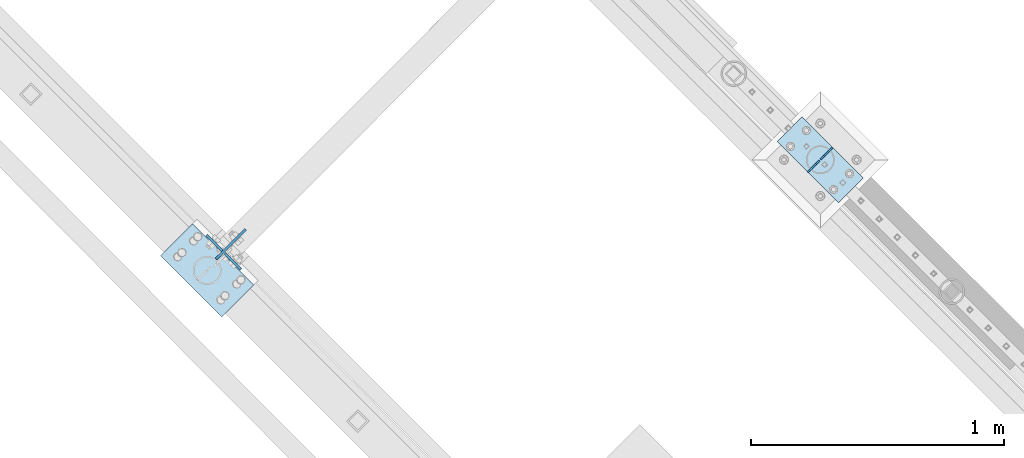
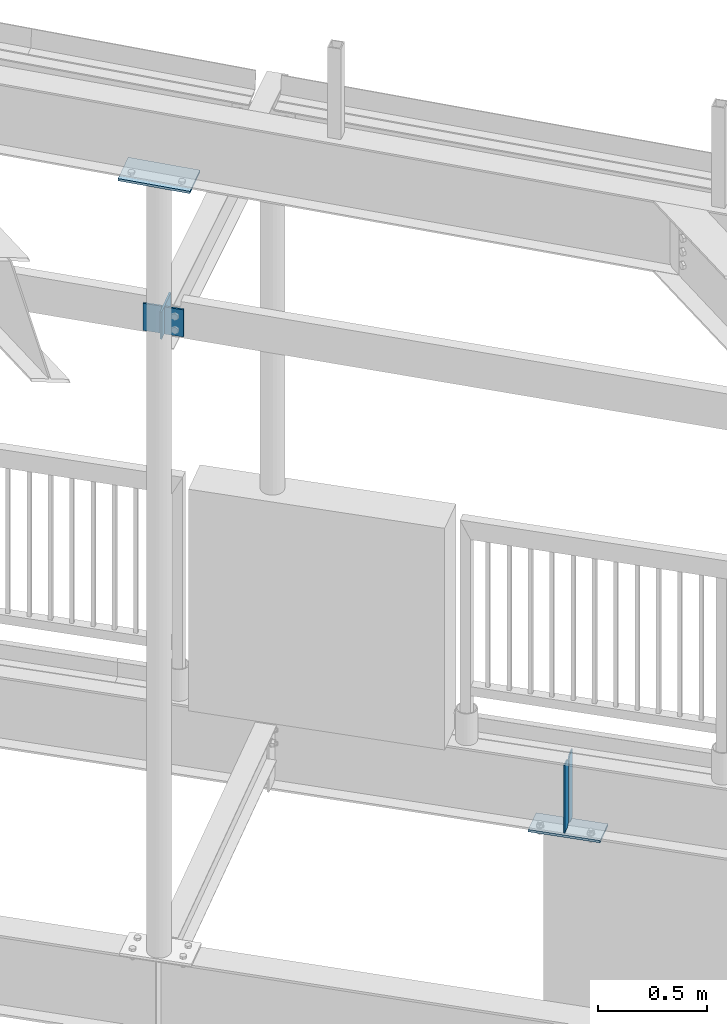
# One storey, part 926 of 975: 7 plates.
"""IFC2X3 building model written with IfcOpenShell, lengths in millimetres."""

from ifc_helpers import new_model, si_unit, frame, origin_with_axes, place, context, subcontext, project, spatial, faceted_brep, material, type_object, element, save


model = new_model("IFC2X3")

# Units and contexts
model_context = context("Model", 3, precision=1e-05, world=origin_with_axes())
body_context = subcontext(model_context, "Body", "Model", "MODEL_VIEW")
ifc_project = project(units=[si_unit("LENGTHUNIT", "METRE", prefix="MILLI"), si_unit("AREAUNIT", "SQUARE_METRE"), si_unit("VOLUMEUNIT", "CUBIC_METRE"), si_unit("MASSUNIT", "GRAM", prefix="KILO"), si_unit("TIMEUNIT", "SECOND"), si_unit("PLANEANGLEUNIT", "RADIAN"), si_unit("SOLIDANGLEUNIT", "STERADIAN"), si_unit("THERMODYNAMICTEMPERATUREUNIT", "DEGREE_CELSIUS"), si_unit("LUMINOUSINTENSITYUNIT", "LUMEN")], contexts=[model_context])

# Site, building, storey
site_placement = place(None, origin_with_axes())
site = spatial("IfcSite", under=ifc_project, at=site_placement, CompositionType="ELEMENT")
building_placement = place(site_placement, origin_with_axes())
building = spatial("IfcBuilding", under=site, at=building_placement, Name="Undefined", CompositionType="ELEMENT")
storey_placement = place(building_placement, origin_with_axes())
storey = spatial("IfcBuildingStorey", under=building, at=storey_placement, Name="Undefined", CompositionType="ELEMENT", Elevation=0.0)

# Plates
ifc_material = material(Name="STEEL/A36")
plate_type_1 = type_object("IfcPlateType", PredefinedType="NOTDEFINED")
plate_1_placement = place(storey_placement, frame((28156.5108960841, 17697.2556712254, 7498.16585916097), z_axis=(0.706418897920462, 0.70779399592031, 0.0), x_axis=(0.0, 0.0, -1.0)))
element("IfcPlate", 1, at=plate_1_placement, inside=storey, type_object=plate_type_1, material=ifc_material, Name="PLATE", context=body_context, shape_type="Brep", body=[
    faceted_brep([(0.0, -4.76250000000073, 0.0), (-2.81943357549608e-11, -4.76249999991887, 165.095245361295), (-2.81943357549608e-11, 4.76250000008076, 165.095245361288), (0.0, 4.76250000000073, 0.0), (152.399993896484, -4.76249999991887, 165.095245361295), (152.399993896484, 4.76250000008076, 165.095245361288), (152.399993896484, -4.76250000000073, 0.0), (152.399993896484, 4.76250000000073, 0.0)], [[[0, 1, 2, 3]], [[1, 4, 5, 2]], [[4, 6, 7, 5]], [[6, 0, 3, 7]], [[5, 7, 3, 2]], [[6, 4, 1, 0]]]),
])
plate_type_2 = type_object("IfcPlateType", PredefinedType="NOTDEFINED")
for number, where, z_axis, x_axis, name in (
    (2, (30496.4898399208, 18039.3773399208, 3925.88750000001), (0.0, 0.0, -1.0), (0.707106781186548, 0.707106781186548, 0.0), "PLATE"),
    (3, (30595.2726572519, 18138.1601572519, 3925.88750000001), (0.0, 0.0, -1.0), (-0.707106781186548, -0.707106781186548, 0.0), "PLATE"),
):
    element("IfcPlate", number, at=place(storey_placement, frame(where, z_axis=z_axis, x_axis=x_axis)), inside=storey, type_object=plate_type_2, material=ifc_material, Name=name, context=body_context, shape_type="Brep", body=[
        faceted_brep([(0.0, -3.17499999999927, 0.0), (1.83717929758132e-10, -3.17499999972279, 381.000000000335), (1.90993887372315e-10, 3.17500000029031, 381.000000000333), (0.0, 3.17499999999927, 0.0), (47.6250038151447, -3.17500000000291, 380.9999999998), (47.6250038151411, 3.17500000000109, 380.999999999805), (66.6750030521871, -3.17500000001564, 361.95000076275), (66.6750030521871, 3.17499999998654, 361.950000762756), (66.6750030518015, -3.17500000004475, 19.0499992370478), (66.6750030517978, 3.17499999995925, 19.0499992370533), (47.625, -3.17499999999927, 0.0), (47.625, 3.17499999999927, 0.0)], [[[0, 1, 2, 3]], [[1, 4, 5, 2]], [[4, 6, 7, 5]], [[6, 8, 9, 7]], [[8, 10, 11, 9]], [[10, 0, 3, 11]], [[5, 7, 9, 11, 3, 2]], [[10, 8, 6, 4, 1, 0]]]),
    ])
plate_type_3 = type_object("IfcPlateType", PredefinedType="NOTDEFINED")
for number, where, z_axis, x_axis, name in (
    (4, (28181.1765807812, 17728.7188835027, 7506.82074122725), (-0.706980057333141, 0.70723348233326, 0.0), (0.0, 0.0, -1.0), "PLATE"),
    (5, (28191.2853202357, 17718.6065229008, 7504.73492577027), (0.706980057333141, -0.70723348233326, 0.0), (0.0, 0.0, -1.0), "PLATE"),
):
    element("IfcPlate", number, at=place(storey_placement, frame(where, z_axis=z_axis, x_axis=x_axis)), inside=storey, type_object=plate_type_3, material=ifc_material, Name=name, context=body_context, shape_type="Brep", body=[
        faceted_brep([(0.0, -4.76250000000073, 0.0), (0.0, -4.76249999999982, 88.9000015258789), (0.0, 4.76249999999982, 88.9000015258789), (0.0, 4.76250000000073, 0.0), (152.399993896484, -4.76249999999982, 88.9000015258789), (152.399993896484, 4.76249999999982, 88.9000015258789), (152.399993896484, -4.76250000000073, 0.0), (152.399993896484, 4.76250000000073, 0.0)], [[[0, 1, 2, 3]], [[1, 4, 5, 2]], [[4, 6, 7, 5]], [[6, 0, 3, 7]], [[5, 7, 3, 2]], [[6, 4, 1, 0]]]),
    ])
plate_type_4 = type_object("IfcPlateType", PredefinedType="NOTDEFINED")
plate_2_placement = place(storey_placement, frame((28305.0772349399, 17593.590479479, 8300.40484727707), z_axis=(-0.706788690770668, 0.706788690944904, 0.0299915479939673), x_axis=(-0.707106895176348, -0.707106667176346, -5.36900000063523e-06)))
element("IfcPlate", 6, at=plate_2_placement, inside=storey, type_object=plate_type_4, material=ifc_material, Name="PLATE", context=body_context, shape_type="Brep", body=[
    faceted_brep([(0.0, -6.34999999998763, -3.63797880709171e-12), (-4.32919478043914e-10, -6.34999999999991, 342.899993895661), (-4.32919478043914e-10, 6.34999999999991, 342.899993895661), (0.0, 6.34999999999491, 5.45696821063757e-12), (177.800003051329, -6.34999999999991, 342.899993895658), (177.800003051329, 6.34999999999991, 342.899993895658), (177.800003051329, -6.34999999999991, -2.22826201934367e-10), (177.800003051329, 6.34999999999991, -2.22826201934367e-10)], [[[0, 1, 2, 3]], [[1, 4, 5, 2]], [[4, 6, 7, 5]], [[6, 0, 3, 7]], [[5, 7, 3, 2]], [[6, 4, 1, 0]]]),
])
plate_type_5 = type_object("IfcPlateType", PredefinedType="NOTDEFINED")
plate_3_placement = place(storey_placement, frame((30717.2998662999, 18017.7204510316, 3527.425), z_axis=(-0.707106781186601, 0.707106781186494, 2.36468622460961e-14), x_axis=(-0.707106781186548, -0.707106781186548, 0.0)))
element("IfcPlate", 7, at=plate_3_placement, inside=storey, type_object=plate_type_5, material=ifc_material, Name="PLATE", context=body_context, shape_type="Brep", body=[
    faceted_brep([(0.0, -6.34999999998763, -3.63797880709171e-12), (-4.32919478043914e-10, -6.34999999999991, 342.899993895661), (-4.32919478043914e-10, 6.34999999999991, 342.899993895661), (0.0, 6.34999999999491, 5.45696821063757e-12), (139.699996947915, -6.34999999999991, 342.899993895657), (139.699996947915, 6.34999999999991, 342.899993895657), (139.699996948082, -6.35000000003311, 8.73114913702011e-11), (139.699996948071, 6.34999999997308, 8.00355337560177e-11)], [[[0, 1, 2, 3]], [[1, 4, 5, 2]], [[4, 6, 7, 5]], [[6, 0, 3, 7]], [[5, 7, 3, 2]], [[6, 4, 1, 0]]]),
])

save(model, "model.ifc")
